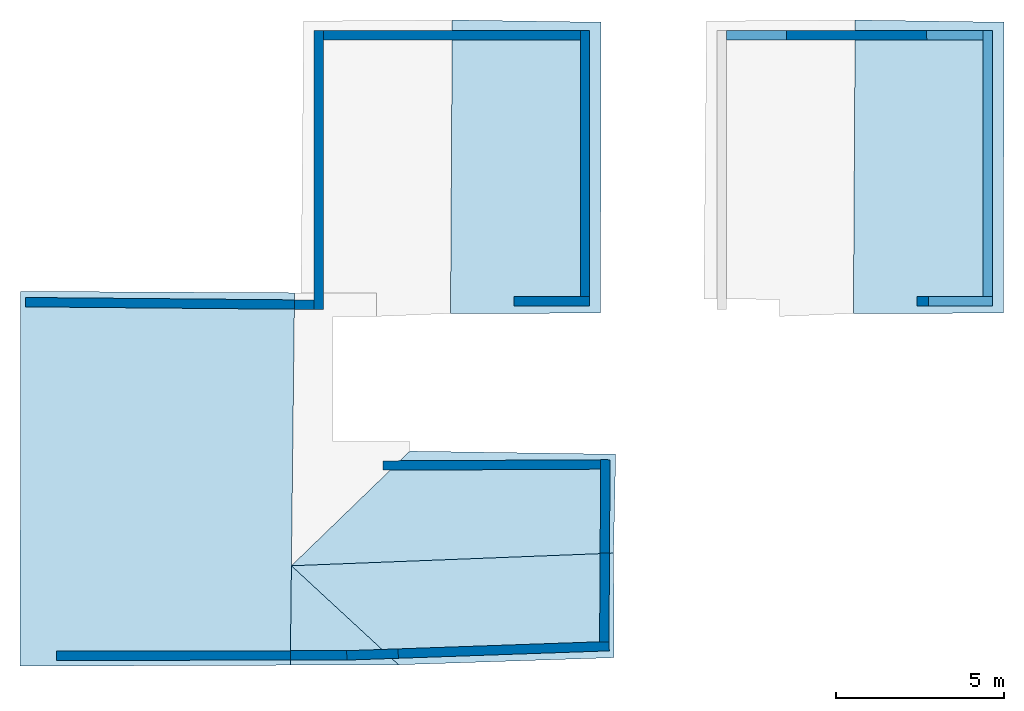
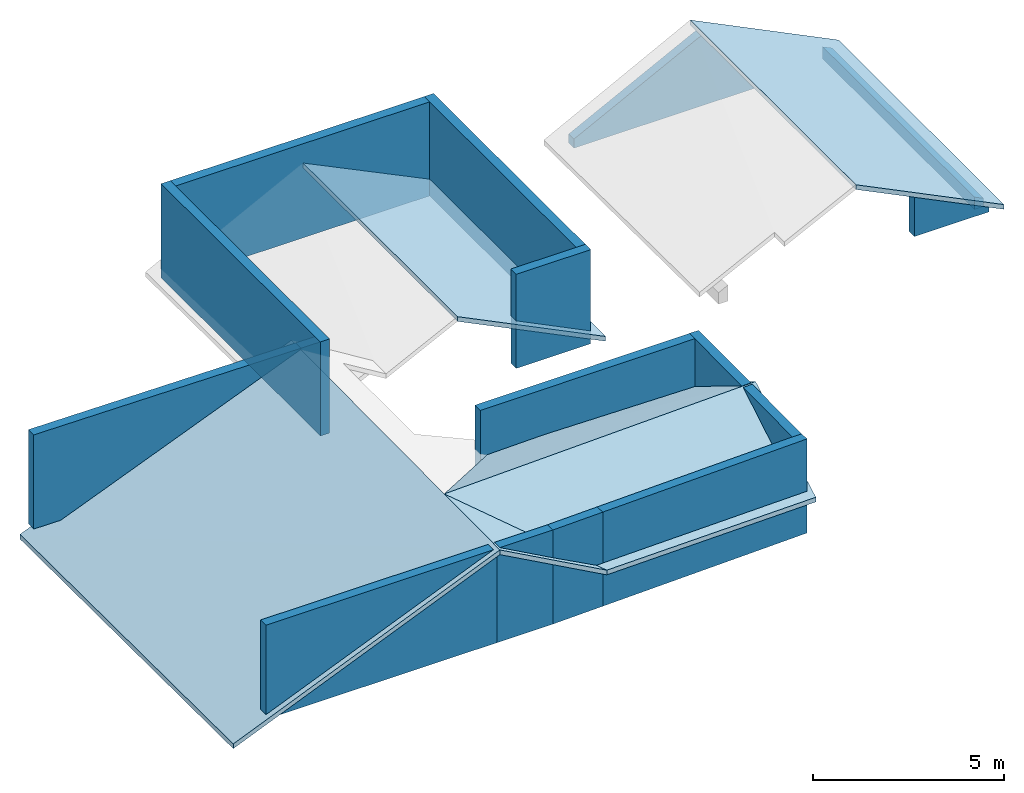
# One storey, part 1 of 2: 28 walls, 8 slabs.
"""IFC4 building model written with IfcOpenShell, lengths in metres."""

from ifc_helpers import new_model, entity, si_unit, converted_unit, frame, frame_2d, origin_with_axes, place, context, subcontext, project, spatial, indexed_curve, outline, extrude, polygons, material, layer, layer_set, layer_usage, type_object, element, save


model = new_model("IFC4")

# Units and contexts
model_context = context("Model", 3, precision=1e-05, world=origin_with_axes())
plan_context = context("Plan", 2, precision=1e-05, world=frame_2d((0.0, 0.0, 0.0), x_axis=(1.0, 0.0, 0.0)))
body_context = subcontext(model_context, "Body", "Model", "MODEL_VIEW")
ifc_project = project(units=[converted_unit("PLANEANGLEUNIT", "degree", entity("IfcReal", 0.0174532925199433), si_unit("PLANEANGLEUNIT", "RADIAN"), dimensions=[0, 0, 0, 0, 0, 0, 0]), si_unit("AREAUNIT", "SQUARE_METRE"), si_unit("VOLUMEUNIT", "CUBIC_METRE"), si_unit("LENGTHUNIT", "METRE")], contexts=[model_context, plan_context])

# Site, building, storey
site_placement = place(None, origin_with_axes())
site = spatial("IfcSite", under=ifc_project, at=site_placement)
building_placement = place(site_placement, origin_with_axes())
building = spatial("IfcBuilding", under=site, at=building_placement, Name="Building")
storey_placement = place(building_placement, frame((0.0, 0.0, 3.0), z_axis=(0.0, 0.0, 1.0), x_axis=(1.0, 0.0, 0.0)))
storey = spatial("IfcBuildingStorey", under=building, at=storey_placement, Name="Dachgeschoss")

# Slabs
slab_1_placement = place(storey_placement, frame((0.138327658176422, 11.9685554504395, -0.0325007438659668), z_axis=(-0.389843016862869, 1.06302975311223e-08, 0.920881330966949), x_axis=(0.920881330966949, -5.23788585837792e-08, 0.389843016862869)))
element("IfcSlab", 1, at=slab_1_placement, inside=storey, Name="roof_wohnen", PredefinedType="ROOF", context=body_context, shape_type="Tessellation", body=[
    polygons([(0.139375194907188, -0.0453592203557491, -0.456899970769882), (0.15936766564846, -11.2182168960571, -0.357028633356094), (0.0808987393975258, -0.0453592240810394, -0.595032215118408), (0.100891202688217, -11.2182168960571, -0.495160847902298), (8.96628284454346, -0.0885668694972992, -0.54577898979187), (8.88335037231445, -11.1898832321167, -0.415635466575623), (8.82487392425537, -11.1898832321167, -0.553767681121826), (8.90780639648438, -0.0885668694972992, -0.683911144733429)], [[[1, 5, 8, 3]], [[1, 3, 4, 2]], [[7, 6, 2, 4]], [[6, 7, 8, 5]], [[1, 6, 5]], [[3, 7, 4]], [[1, 2, 6]], [[3, 8, 7]]]),
])
slab_2_placement = place(storey_placement, frame((7.51337957382202, 18.4299716949463, 3.13837957382202), z_axis=(0.0, 0.0, 1.0), x_axis=(1.0, 0.0, 0.0)))
element("IfcSlab", 2, at=slab_2_placement, inside=storey, PredefinedType="ROOF", context=body_context, shape_type="Tessellation", body=[
    polygons([(0.967490494251251, -17.6513004302979, -0.0905194282531738), (4.19703483581543, -17.6393585205078, -1.87382221221924), (1.00142824649811, -14.6873569488525, -0.113885402679443), (1.00142824649811, -14.6873569488525, -0.263885408639908), (0.967490494251251, -17.6513004302979, -0.240519434213638), (4.19703483581543, -17.6393585205078, -2.02382230758667)], [[[3, 1, 2]], [[4, 6, 5]], [[3, 2, 6, 4]], [[2, 1, 5, 6]], [[1, 3, 4, 5]]]),
])
slab_3_placement = place(storey_placement, frame((11.5073595046997, 19.0338859558105, -0.612094879150391), z_axis=(0.0, 0.0, 1.0), x_axis=(1.0, 0.0, 0.0)))
element("IfcSlab", 3, at=slab_3_placement, inside=storey, Name="dach_n", PredefinedType="ROOF", context=body_context, shape_type="Tessellation", body=[
    polygons([(0.20305597782135, -18.2432727813721, 1.87665224075317), (6.62885904312134, -18.0298824310303, 1.82354259490967), (-2.99255204200745, -15.2912702560425, 3.63658905029297), (6.6104941368103, -14.9145994186401, 3.63154697418213), (-2.99255204200745, -15.2912702560425, 3.48658895492554), (0.20305597782135, -18.2432727813721, 1.72665226459503), (6.62885904312134, -18.0298824310303, 1.67354261875153), (6.6104941368103, -14.9145994186401, 3.4815468788147)], [[[1, 4, 2]], [[6, 8, 5]], [[2, 4, 8, 7]], [[3, 1, 6, 5]], [[4, 3, 5, 8]], [[1, 2, 7, 6]], [[1, 3, 4]], [[6, 7, 8]]]),
])
slab_4_placement = place(storey_placement, frame((11.5073595046997, 19.0338859558105, -0.612094879150391), z_axis=(0.0, 0.0, 1.0), x_axis=(1.0, 0.0, 0.0)))
element("IfcSlab", 4, at=slab_4_placement, inside=storey, Name="dach_s", PredefinedType="ROOF", context=body_context, shape_type="Tessellation", body=[
    polygons([(-2.99255204200745, -15.2912702560425, 3.63658905029297), (6.61049318313599, -14.9145994186401, 3.63154697418213), (0.53916323184967, -11.8741445541382, 1.83055698871613), (6.67501163482666, -11.9667654037476, 1.80503046512604), (0.53916323184967, -11.8741445541382, 1.68055701255798), (-2.99255204200745, -15.2912702560425, 3.48658895492554), (6.61049318313599, -14.9145994186401, 3.4815468788147), (6.67501163482666, -11.9667654037476, 1.6550304889679)], [[[3, 2, 1]], [[7, 5, 6]], [[2, 4, 8, 7]], [[3, 6, 5]], [[4, 3, 5, 8]], [[1, 2, 7, 6]], [[3, 4, 2]], [[7, 8, 5]], [[3, 1, 6]]]),
])
for number, where, z_axis, x_axis, name in (
    (5, (14.0933465957642, 19.4814624786377, 1.75806331634521), (0.83547306060791, 6.05244423468321e-08, 0.54953134059906), (0.54953134059906, 1.12253204065382e-07, -0.83547306060791), "dach_sw"),
    (6, (14.0933465957642, 19.4814624786377, 1.75806331634521), (0.83547306060791, 6.05244423468321e-08, 0.54953134059906), (0.54953134059906, 1.12253204065382e-07, -0.83547306060791), "dach_sw"),
    (7, (14.0933465957642, 19.4814624786377, 1.75806331634521), (0.83547306060791, 6.05244423468321e-08, 0.54953134059906), (0.54953134059906, 1.12253204065382e-07, -0.83547306060791), "dach_sw"),
):
    element("IfcSlab", number, at=place(storey_placement, frame(where, z_axis=z_axis, x_axis=x_axis)), inside=storey, Name=name, PredefinedType="ROOF", context=body_context, shape_type="Tessellation", body=[
        polygons([(-1.04153060913086, -8.217942237854, -0.316155582666397), (3.25821256637573, -8.2083625793457, 2.20982432365417), (-0.953627169132233, 0.529778599739075, -0.311261177062988), (3.28126811981201, 0.463787794113159, 2.21388936042786), (-0.980952382087708, -2.60569453239441, -5.8044319152832), (-0.828306198120117, 0.529778599739075, -0.393690884113312), (-0.916209638118744, -8.217942237854, -0.398585289716721), (3.38353371620178, -8.2083625793457, 2.1273946762085), (3.40658903121948, 0.463787794113159, 2.13145971298218)], [[[1, 4, 2]], [[7, 9, 6]], [[2, 4, 9, 8]], [[3, 1, 7, 6]], [[4, 3, 6, 9]], [[1, 2, 8, 7]], [[1, 3, 4]], [[7, 8, 9]]]),
    ])
slab_5_placement = place(storey_placement, frame((26.103214263916, 19.4814624786377, 1.75806331634521), z_axis=(0.835473120212555, 6.05244707685415e-08, 0.549531161785126), x_axis=(0.549531161785126, 1.1225321117081e-07, -0.835473120212555)))
element("IfcSlab", 8, at=slab_5_placement, inside=storey, Name="dach_sw.001", PredefinedType="ROOF", context=body_context, shape_type="Tessellation", body=[
    polygons([(-1.04153060913086, -8.217942237854, -0.316155582666397), (3.25821256637573, -8.2083625793457, 2.20982432365417), (3.28126811981201, 0.463787794113159, 2.21388936042786), (-0.828306198120117, 0.529778599739075, -0.393690884113312), (-0.916209638118744, -8.217942237854, -0.398585289716721), (3.40658903121948, 0.463787794113159, 2.13145971298218), (3.38353371620178, -8.2083625793457, 2.1273946762085), (-0.953627169132233, 0.529778599739075, -0.311261177062988)], [[[5, 6, 7]], [[6, 4, 8, 3]], [[4, 5, 1, 8]], [[1, 3, 8]], [[7, 2, 1, 5]], [[3, 2, 7, 6]], [[5, 4, 6]], [[1, 2, 3]]]),
])

# Walls
ifc_material = material(Name="aussenwand_280_material")
ifc_layer = layer(ifc_material, 0.280000001192093)
ifc_layer_set = layer_set([ifc_layer])
ifc_layer_usage_1 = layer_usage(ifc_layer_set, "AXIS2", "POSITIVE", 0.0)
wall_type = type_object("IfcWallType", Name="aussenwand_280", PredefinedType="STANDARD", material=ifc_layer_set)
wall_1_placement = place(storey_placement, frame((9.18882751464844, 19.7012138366699, -2.38418579101563e-07), z_axis=(0.0, 0.0, 1.0), x_axis=(-1.62920684942947e-07, -1.0, 0.0)))
element("IfcWall", 9, at=wall_1_placement, inside=storey, type_object=wall_type, material=ifc_layer_usage_1, Name="Wall", PredefinedType="NOTDEFINED", context=body_context, shape_type="SweptSolid", body=[
    extrude(outline(indexed_curve([(0.0, 0.0), (0.0, 0.280000001192093), (8.31982420442171, 0.280000001192093), (8.31982420442171, 0.0), (0.0, 0.0)], self_intersect=False)), origin_with_axes(), (0.0, 0.0, 1.0), 3.0),
])
ifc_layer_usage_2 = layer_usage(ifc_layer_set, "AXIS2", "POSITIVE", 0.0)
wall_2_placement = place(storey_placement, frame((1.50885987281799, 0.922550857067108, -2.38418579101563e-07), z_axis=(0.0, 0.0, 1.0), x_axis=(0.999999582767487, 0.000923240790143609, 0.0)))
element("IfcWall", 10, at=wall_2_placement, inside=storey, type_object=wall_type, material=ifc_layer_usage_2, Name="Wall", PredefinedType="NOTDEFINED", context=body_context, shape_type="SweptSolid", body=[
    extrude(outline(indexed_curve([(0.0, 0.0), (0.0, 0.280000001192093), (6.97187437102741, 0.280000001192093), (6.97187437102741, 0.0), (0.0, 0.0)], self_intersect=False)), origin_with_axes(), (0.0, 0.0, 1.0), 3.0),
])
ifc_layer_usage_3 = layer_usage(ifc_layer_set, "AXIS2", "POSITIVE", 0.0)
wall_3_placement = place(storey_placement, frame((10.1700124740601, 0.931393384933472, -2.38418579101563e-07), z_axis=(0.0, 0.0, 1.0), x_axis=(0.999382197856903, 0.0351415351033211, 0.0)))
element("IfcWall", 11, at=wall_3_placement, inside=storey, type_object=wall_type, material=ifc_layer_usage_3, Name="Wall", PredefinedType="NOTDEFINED", context=body_context, shape_type="SweptSolid", body=[
    extrude(outline(indexed_curve([(0.0, 0.0), (0.0, 0.280000001192093), (1.53450472655644, 0.280000001192093), (1.53450472655644, 0.0), (0.0, 0.0)], self_intersect=False)), origin_with_axes(), (0.0, 0.0, 1.0), 3.0),
])
ifc_layer_usage_4 = layer_usage(ifc_layer_set, "AXIS2", "POSITIVE", 0.0)
wall_4_placement = place(storey_placement, frame((17.7329654693604, 6.90121555328369, -2.38418579101563e-07), z_axis=(0.0, 0.0, 1.0), x_axis=(-0.999989092350006, -0.00467242300510406, 0.0)))
element("IfcWall", 12, at=wall_4_placement, inside=storey, type_object=wall_type, material=ifc_layer_usage_4, Name="Wall", PredefinedType="NOTDEFINED", context=body_context, shape_type="SweptSolid", body=[
    extrude(outline(indexed_curve([(0.0, 0.0), (0.0, 0.280000001192093), (6.4844628440617, 0.280000001192093), (6.4844628440617, 0.0), (0.0, 0.0)], self_intersect=False)), origin_with_axes(), (0.0, 0.0, 1.0), 3.0),
])
ifc_layer_usage_5 = layer_usage(ifc_layer_set, "AXIS2", "POSITIVE", 0.0)
wall_5_placement = place(storey_placement, frame((9.19131374359131, 11.6638669967651, -2.38418579101563e-07), z_axis=(0.0, 0.0, 1.0), x_axis=(-0.999960541725159, 0.00888374913483858, 0.0)))
element("IfcWall", 13, at=wall_5_placement, inside=storey, type_object=wall_type, material=ifc_layer_usage_5, Name="Wall", PredefinedType="NOTDEFINED", context=body_context, shape_type="SweptSolid", body=[
    extrude(outline(indexed_curve([(0.0, 0.0), (0.0, 0.280000001192093), (0.585232937038386, 0.280000001192093), (0.585232937038386, 0.0), (0.0, 0.0)], self_intersect=False)), origin_with_axes(), (0.0, 0.0, 1.0), 3.0),
])
ifc_layer_usage_6 = layer_usage(ifc_layer_set, "AXIS2", "POSITIVE", 0.0)
wall_6_placement = place(storey_placement, frame((9.46882724761963, 19.4212131500244, -2.38418579101563e-07), z_axis=(0.0, 0.0, 1.0), x_axis=(1.0, 0.0, 0.0)))
element("IfcWall", 14, at=wall_6_placement, inside=storey, type_object=wall_type, material=ifc_layer_usage_6, Name="Wall", PredefinedType="NOTDEFINED", context=body_context, shape_type="SweptSolid", body=[
    extrude(outline(indexed_curve([(0.0, 0.0), (0.0, 0.280000001192093), (7.65666477870406, 0.280000001192093), (7.65666477870406, 0.0), (0.0, 0.0)], self_intersect=False)), origin_with_axes(), (0.0, 0.0, 1.0), 3.0),
])
ifc_layer_usage_7 = layer_usage(ifc_layer_set, "AXIS2", "POSITIVE", 0.0)
wall_7_placement = place(storey_placement, frame((17.732982635498, 6.90418434143066, -2.38418579101563e-07), z_axis=(0.0, 0.0, 1.0), x_axis=(-0.00592900207266212, -0.999982416629791, 0.0)))
element("IfcWall", 15, at=wall_7_placement, inside=storey, type_object=wall_type, material=ifc_layer_usage_7, Name="Wall", PredefinedType="NOTDEFINED", context=body_context, shape_type="SweptSolid", body=[
    extrude(outline(indexed_curve([(0.0, 0.0), (0.0, 0.280000001192093), (2.78256681753973, 0.280000001192093), (2.78256681753973, 0.0), (0.0, 0.0)], self_intersect=False)), origin_with_axes(), (0.0, 0.0, 1.0), 3.0),
])
ifc_layer_usage_8 = layer_usage(ifc_layer_set, "AXIS2", "POSITIVE", 0.0)
wall_8_placement = place(storey_placement, frame((15.1564960479736, 11.4919033050537, -2.38418579101563e-07), z_axis=(0.0, 0.0, 1.0), x_axis=(1.0, 0.0, 0.0)))
element("IfcWall", 16, at=wall_8_placement, inside=storey, type_object=wall_type, material=ifc_layer_usage_8, Name="Wall", PredefinedType="NOTDEFINED", context=body_context, shape_type="SweptSolid", body=[
    extrude(outline(indexed_curve([(0.0, 0.0), (0.0, 0.280000001192093), (2.24899481466534, 0.280000001192093), (2.24899481466534, 0.0), (0.0, 0.0)], self_intersect=False)), origin_with_axes(), (0.0, 0.0, 1.0), 3.0),
])
ifc_layer_usage_9 = layer_usage(ifc_layer_set, "AXIS2", "POSITIVE", 0.0)
wall_9_placement = place(storey_placement, frame((17.1254920959473, 19.7012138366699, -2.38418579101563e-07), z_axis=(0.0, 0.0, 1.0), x_axis=(-1.62920684942947e-07, -1.0, 0.0)))
element("IfcWall", 17, at=wall_9_placement, inside=storey, type_object=wall_type, material=ifc_layer_usage_9, Name="Wall", PredefinedType="NOTDEFINED", context=body_context, shape_type="SweptSolid", body=[
    extrude(outline(indexed_curve([(0.0, 0.0), (0.0, 0.280000001192093), (7.92931081694632, 0.280000001192093), (7.92931081694632, 0.0), (0.0, 0.0)], self_intersect=False)), origin_with_axes(), (0.0, 0.0, 1.0), 3.0),
])
ifc_layer_usage_10 = layer_usage(ifc_layer_set, "AXIS2", "POSITIVE", 0.0)
wall_10_placement = place(storey_placement, frame((8.4807300567627, 0.929833590984344, -2.38418579101563e-07), z_axis=(0.0, 0.0, 1.0), x_axis=(0.999999582767487, 0.000923240790143609, 0.0)))
element("IfcWall", 18, at=wall_10_placement, inside=storey, type_object=wall_type, material=ifc_layer_usage_10, Name="Wall", PredefinedType="NOTDEFINED", context=body_context, shape_type="SweptSolid", body=[
    extrude(outline(indexed_curve([(0.0, 0.0), (0.0, 0.280000001192093), (1.68927835094324, 0.280000001192093), (1.68927835094324, 0.0), (0.0, 0.0)], self_intersect=False)), origin_with_axes(), (0.0, 0.0, 1.0), 3.0),
])
ifc_layer_usage_11 = layer_usage(ifc_layer_set, "AXIS2", "POSITIVE", 0.0)
wall_11_placement = place(storey_placement, frame((11.7035694122314, 0.985318243503571, -2.38418579101563e-07), z_axis=(0.0, 0.0, 1.0), x_axis=(0.999382138252258, 0.0351415351033211, 0.0)))
element("IfcWall", 19, at=wall_11_placement, inside=storey, type_object=wall_type, material=ifc_layer_usage_11, Name="Wall", PredefinedType="NOTDEFINED", context=body_context, shape_type="SweptSolid", body=[
    extrude(outline(indexed_curve([(0.0, 0.0), (0.0, 0.280000001192093), (6.29101780503812, 0.280000001192093), (6.29101780503812, 0.0), (0.0, 0.0)], self_intersect=False)), origin_with_axes(), (0.0, 0.0, 1.0), 3.0),
])
ifc_layer_usage_12 = layer_usage(ifc_layer_set, "AXIS2", "POSITIVE", 0.0)
wall_12_placement = place(storey_placement, frame((17.7164840698242, 4.121666431427, -2.38418579101563e-07), z_axis=(0.0, 0.0, 1.0), x_axis=(-0.00592900207266212, -0.999982416629791, 0.0)))
element("IfcWall", 20, at=wall_12_placement, inside=storey, type_object=wall_type, material=ifc_layer_usage_12, Name="Wall", PredefinedType="NOTDEFINED", context=body_context, shape_type="SweptSolid", body=[
    extrude(outline(indexed_curve([(0.0, 0.0), (0.0, 0.280000001192093), (2.64533971893712, 0.280000001192093), (2.64533971893712, 0.0), (0.0, 0.0)], self_intersect=False)), origin_with_axes(), (0.0, 0.0, 1.0), 3.0),
])
ifc_layer_usage_13 = layer_usage(ifc_layer_set, "AXIS2", "POSITIVE", 0.0)
wall_13_placement = place(storey_placement, frame((8.60610389709473, 11.6690664291382, -0.0010533332824707), z_axis=(0.0, 0.0, 1.0), x_axis=(-0.999960541725159, 0.00888374913483858, 0.0)))
element("IfcWall", 21, at=wall_13_placement, inside=storey, type_object=wall_type, material=ifc_layer_usage_13, Name="Wall", PredefinedType="NOTDEFINED", context=body_context, shape_type="SweptSolid", body=[
    extrude(outline(indexed_curve([(0.0, 0.0), (0.0, 0.280000001192093), (8.01390124085017, 0.280000001192093), (8.01390124085017, 0.0), (0.0, 0.0)], self_intersect=False)), origin_with_axes(), (0.0, 0.0, 1.0), 3.0),
])
ifc_layer_usage_14 = layer_usage(ifc_layer_set, "AXIS2", "POSITIVE", 0.0)
wall_14_placement = place(storey_placement, frame((15.1564960479736, 11.4919033050537, -2.38418579101563e-07), z_axis=(0.0, 0.0, 1.0), x_axis=(1.0, 0.0, 0.0)))
element("IfcWall", 22, at=wall_14_placement, inside=storey, type_object=wall_type, material=ifc_layer_usage_14, Name="Wall", PredefinedType="NOTDEFINED", context=body_context, shape_type="SweptSolid", body=[
    extrude(outline(indexed_curve([(0.0, 0.0), (0.0, 0.280000001192093), (2.24899481466534, 0.280000001192093), (2.24899481466534, 0.0), (0.0, 0.0)], self_intersect=False)), origin_with_axes(), (0.0, 0.0, 1.0), 3.0),
])
ifc_layer_usage_15 = layer_usage(ifc_layer_set, "AXIS2", "POSITIVE", 0.0)
wall_15_placement = place(storey_placement, frame((17.1254920959473, 19.7012138366699, -2.38418579101563e-07), z_axis=(0.0, 0.0, 1.0), x_axis=(-1.62920684942947e-07, -1.0, 0.0)))
element("IfcWall", 23, at=wall_15_placement, inside=storey, type_object=wall_type, material=ifc_layer_usage_15, Name="Wall", PredefinedType="NOTDEFINED", context=body_context, shape_type="SweptSolid", body=[
    extrude(outline(indexed_curve([(0.0, 0.0), (0.0, 0.280000001192093), (7.92931081694632, 0.280000001192093), (7.92931081694632, 0.0), (0.0, 0.0)], self_intersect=False)), origin_with_axes(), (0.0, 0.0, 1.0), 3.0),
])
ifc_layer_usage_16 = layer_usage(ifc_layer_set, "AXIS2", "POSITIVE", 0.0)
wall_16_placement = place(storey_placement, frame((9.46882724761963, 19.4212131500244, -2.38418579101563e-07), z_axis=(0.0, 0.0, 1.0), x_axis=(1.0, 0.0, 0.0)))
element("IfcWall", 24, at=wall_16_placement, inside=storey, type_object=wall_type, material=ifc_layer_usage_16, Name="Wall", PredefinedType="NOTDEFINED", context=body_context, shape_type="SweptSolid", body=[
    extrude(outline(indexed_curve([(0.0, 0.0), (0.0, 0.280000001192093), (7.65666477870406, 0.280000001192093), (7.65666477870406, 0.0), (0.0, 0.0)], self_intersect=False)), origin_with_axes(), (0.0, 0.0, 1.0), 3.0),
])
ifc_layer_usage_17 = layer_usage(ifc_layer_set, "AXIS2", "POSITIVE", 0.0)
wall_17_placement = place(storey_placement, frame((9.18882751464844, 19.7012138366699, -2.38418579101563e-07), z_axis=(0.0, 0.0, 1.0), x_axis=(-1.62920684942947e-07, -1.0, 0.0)))
element("IfcWall", 25, at=wall_17_placement, inside=storey, type_object=wall_type, material=ifc_layer_usage_17, Name="Wall", PredefinedType="NOTDEFINED", context=body_context, shape_type="SweptSolid", body=[
    extrude(outline(indexed_curve([(0.0, 0.0), (0.0, 0.280000001192093), (8.31982420442171, 0.280000001192093), (8.31982420442171, 0.0), (0.0, 0.0)], self_intersect=False)), origin_with_axes(), (0.0, 0.0, 1.0), 3.0),
])
ifc_layer_usage_18 = layer_usage(ifc_layer_set, "AXIS2", "POSITIVE", 0.0)
wall_18_placement = place(storey_placement, frame((15.1564960479736, 11.4919033050537, -2.38418579101563e-07), z_axis=(0.0, 0.0, 1.0), x_axis=(1.0, 0.0, 0.0)))
element("IfcWall", 26, at=wall_18_placement, inside=storey, type_object=wall_type, material=ifc_layer_usage_18, Name="Wall", PredefinedType="NOTDEFINED", context=body_context, shape_type="SweptSolid", body=[
    extrude(outline(indexed_curve([(0.0, 0.0), (0.0, 0.280000001192093), (2.24899481466534, 0.280000001192093), (2.24899481466534, 0.0), (0.0, 0.0)], self_intersect=False)), origin_with_axes(), (0.0, 0.0, 1.0), 3.0),
])
ifc_layer_usage_19 = layer_usage(ifc_layer_set, "AXIS2", "POSITIVE", 0.0)
wall_19_placement = place(storey_placement, frame((17.1254920959473, 19.7012138366699, -2.38418579101563e-07), z_axis=(0.0, 0.0, 1.0), x_axis=(-1.62920684942947e-07, -1.0, 0.0)))
element("IfcWall", 27, at=wall_19_placement, inside=storey, type_object=wall_type, material=ifc_layer_usage_19, Name="Wall", PredefinedType="NOTDEFINED", context=body_context, shape_type="SweptSolid", body=[
    extrude(outline(indexed_curve([(0.0, 0.0), (0.0, 0.280000001192093), (7.92931081694632, 0.280000001192093), (7.92931081694632, 0.0), (0.0, 0.0)], self_intersect=False)), origin_with_axes(), (0.0, 0.0, 1.0), 3.0),
])
ifc_layer_usage_20 = layer_usage(ifc_layer_set, "AXIS2", "POSITIVE", 0.0)
wall_20_placement = place(storey_placement, frame((9.46882724761963, 19.4212131500244, -2.38418579101563e-07), z_axis=(0.0, 0.0, 1.0), x_axis=(1.0, 0.0, 0.0)))
element("IfcWall", 28, at=wall_20_placement, inside=storey, type_object=wall_type, material=ifc_layer_usage_20, Name="Wall", PredefinedType="NOTDEFINED", context=body_context, shape_type="SweptSolid", body=[
    extrude(outline(indexed_curve([(0.0, 0.0), (0.0, 0.280000001192093), (7.65666477870406, 0.280000001192093), (7.65666477870406, 0.0), (0.0, 0.0)], self_intersect=False)), origin_with_axes(), (0.0, 0.0, 1.0), 3.0),
])
ifc_layer_usage_21 = layer_usage(ifc_layer_set, "AXIS2", "POSITIVE", 0.0)
wall_21_placement = place(storey_placement, frame((9.18882751464844, 19.7012138366699, -2.38418579101563e-07), z_axis=(0.0, 0.0, 1.0), x_axis=(-1.62920684942947e-07, -1.0, 0.0)))
element("IfcWall", 29, at=wall_21_placement, inside=storey, type_object=wall_type, material=ifc_layer_usage_21, Name="Wall", PredefinedType="NOTDEFINED", context=body_context, shape_type="SweptSolid", body=[
    extrude(outline(indexed_curve([(0.0, 0.0), (0.0, 0.280000001192093), (8.31982420442171, 0.280000001192093), (8.31982420442171, 0.0), (0.0, 0.0)], self_intersect=False)), origin_with_axes(), (0.0, 0.0, 1.0), 3.0),
])
ifc_layer_usage_22 = layer_usage(ifc_layer_set, "AXIS2", "POSITIVE", 0.0)
wall_22_placement = place(storey_placement, frame((15.1564960479736, 11.4919033050537, -2.38418579101563e-07), z_axis=(0.0, 0.0, 1.0), x_axis=(1.0, 0.0, 0.0)))
element("IfcWall", 30, at=wall_22_placement, inside=storey, type_object=wall_type, material=ifc_layer_usage_22, Name="Wall", PredefinedType="NOTDEFINED", context=body_context, shape_type="SweptSolid", body=[
    extrude(outline(indexed_curve([(0.0, 0.0), (0.0, 0.280000001192093), (2.24899481466534, 0.280000001192093), (2.24899481466534, 0.0), (0.0, 0.0)], self_intersect=False)), origin_with_axes(), (0.0, 0.0, 1.0), 3.0),
])
ifc_layer_usage_23 = layer_usage(ifc_layer_set, "AXIS2", "POSITIVE", 0.0)
wall_23_placement = place(storey_placement, frame((17.1254920959473, 19.7012138366699, -2.38418579101563e-07), z_axis=(0.0, 0.0, 1.0), x_axis=(-1.62920684942947e-07, -1.0, 0.0)))
element("IfcWall", 31, at=wall_23_placement, inside=storey, type_object=wall_type, material=ifc_layer_usage_23, Name="Wall", PredefinedType="NOTDEFINED", context=body_context, shape_type="SweptSolid", body=[
    extrude(outline(indexed_curve([(0.0, 0.0), (0.0, 0.280000001192093), (7.92931081694632, 0.280000001192093), (7.92931081694632, 0.0), (0.0, 0.0)], self_intersect=False)), origin_with_axes(), (0.0, 0.0, 1.0), 3.0),
])
ifc_layer_usage_24 = layer_usage(ifc_layer_set, "AXIS2", "POSITIVE", 0.0)
wall_24_placement = place(storey_placement, frame((9.46882724761963, 19.4212131500244, -2.38418579101563e-07), z_axis=(0.0, 0.0, 1.0), x_axis=(1.0, 0.0, 0.0)))
element("IfcWall", 32, at=wall_24_placement, inside=storey, type_object=wall_type, material=ifc_layer_usage_24, Name="Wall", PredefinedType="NOTDEFINED", context=body_context, shape_type="SweptSolid", body=[
    extrude(outline(indexed_curve([(0.0, 0.0), (0.0, 0.280000001192093), (7.65666477870406, 0.280000001192093), (7.65666477870406, 0.0), (0.0, 0.0)], self_intersect=False)), origin_with_axes(), (0.0, 0.0, 1.0), 3.0),
])
ifc_layer_usage_25 = layer_usage(ifc_layer_set, "AXIS2", "POSITIVE", 0.0)
wall_25_placement = place(storey_placement, frame((9.18882751464844, 19.7012138366699, -2.38418579101563e-07), z_axis=(0.0, 0.0, 1.0), x_axis=(-1.62920684942947e-07, -1.0, 0.0)))
element("IfcWall", 33, at=wall_25_placement, inside=storey, type_object=wall_type, material=ifc_layer_usage_25, Name="Wall", PredefinedType="NOTDEFINED", context=body_context, shape_type="SweptSolid", body=[
    extrude(outline(indexed_curve([(0.0, 0.0), (0.0, 0.280000001192093), (8.31982420442171, 0.280000001192093), (8.31982420442171, 0.0), (0.0, 0.0)], self_intersect=False)), origin_with_axes(), (0.0, 0.0, 1.0), 3.0),
])
wall_26_placement = place(storey_placement, frame((29.1353607177734, 19.7012138366699, -2.38418579101562e-07), z_axis=(0.0, 0.0, 1.0), x_axis=(-1.62920684942947e-07, -1.0, 0.0)))
element("IfcWall", 34, at=wall_26_placement, inside=storey, Name="Wall.017", PredefinedType="ELEMENTEDWALL", context=body_context, shape_type="Tessellation", body=[
    polygons([(0.0, 0.0, 0.0), (0.0, 0.280000001192093, 0.0), (7.92931079864502, 0.280000001192093, 0.0), (7.92931079864502, 0.0, 0.0), (7.92931079864502, 0.0, 0.3976731300354), (7.92931079864502, 0.280000001192093, 0.25970184803009), (0.0, 0.0, 0.385388821363449), (0.0, 0.280000001192093, 0.249655932188034)], [[[5, 4, 3, 6]], [[7, 1, 4, 5]], [[2, 1, 7, 8]], [[4, 1, 2, 3]], [[3, 2, 8, 6]]]),
    polygons([(0.0, 0.0, 0.0), (0.0, 0.280000001192093, 0.0), (7.92931079864502, 0.280000001192093, 0.0), (7.92931079864502, 0.0, 0.0), (7.92931079864502, 0.0, 0.3976731300354), (7.92931079864502, 0.280000001192093, 0.25970184803009), (0.0, 0.0, 0.385388821363449), (0.0, 0.280000001192093, 0.249655932188034)], [[[7, 6, 8]], [[7, 5, 6]]]),
])
wall_27_placement = place(storey_placement, frame((21.4786949157715, 19.4212131500244, -2.38418579101562e-07), z_axis=(0.0, 0.0, 1.0), x_axis=(1.0, 0.0, 0.0)))
element("IfcWall", 35, at=wall_27_placement, inside=storey, Name="Wall.018", PredefinedType="ELEMENTEDWALL", context=body_context, shape_type="Tessellation", body=[
    polygons([(0.0, 0.0, 0.0), (0.0, 0.280000001192093, 0.0), (7.65666484832764, 0.280000001192093, 0.0), (7.65666484832764, 0.0, 0.0), (7.65666484832764, 0.0, 0.386841058731079), (7.65666484832764, 0.280000001192093, 0.385389387607574), (3.83688712120056, 0.0, 2.23851776123047), (3.83856415748596, 0.280000001192093, 2.23625302314758), (0.0, 0.0, 0.290171056985855), (3.83688688278198, 0.0, 2.23851752281189), (3.68027377128601, 0.0, 2.16813325881958), (0.0, 0.280000001192093, 0.282527238130569), (3.83856391906738, 0.280000001192093, 2.236252784729), (3.75627207756042, 0.280000001192093, 2.19926977157593)], [[[5, 4, 3, 6]], [[2, 1, 9, 12]], [[4, 1, 2, 3]], [[2, 12, 14, 13, 8, 6, 3]], [[5, 7, 10, 11, 9, 1, 4]]]),
    polygons([(0.0, 0.0, 0.0), (0.0, 0.280000001192093, 0.0), (7.65666484832764, 0.280000001192093, 0.0), (7.65666484832764, 0.0, 0.0), (7.65666484832764, 0.0, 0.386841058731079), (7.65666484832764, 0.280000001192093, 0.385389387607574), (3.83688712120056, 0.0, 2.23851776123047), (3.83856415748596, 0.280000001192093, 2.23625302314758), (0.0, 0.0, 0.290171056985855), (3.83688688278198, 0.0, 2.23851752281189), (3.68027377128601, 0.0, 2.16813325881958), (0.0, 0.280000001192093, 0.282527238130569), (3.83856391906738, 0.280000001192093, 2.236252784729), (3.75627207756042, 0.280000001192093, 2.19926977157593)], [[[8, 7, 5, 6]], [[12, 9, 11, 14]], [[14, 11, 10, 13]]]),
])
wall_28_placement = place(storey_placement, frame((27.1663627624512, 11.4919033050537, -2.38418579101562e-07), z_axis=(0.0, 0.0, 1.0), x_axis=(1.0, 0.0, 0.0)))
element("IfcWall", 36, at=wall_28_placement, inside=storey, Name="Wall.016", PredefinedType="ELEMENTEDWALL", context=body_context, shape_type="Tessellation", body=[
    polygons([(0.0, 0.0, 0.0), (0.0, 0.280000001192093, 0.0), (2.24899482727051, 0.280000001192093, 0.0), (2.24899482727051, 0.0, 0.0), (2.24899482727051, 0.0, 0.259997576475143), (2.24899482727051, 0.280000001192093, 0.259703397750854), (0.0, 0.0, 1.36820006370544), (0.0, 0.280000001192093, 1.36790585517883)], [[[5, 4, 3, 6]], [[7, 1, 4, 5]], [[2, 1, 7, 8]], [[4, 1, 2, 3]], [[3, 2, 8, 6]]]),
    polygons([(0.0, 0.0, 0.0), (0.0, 0.280000001192093, 0.0), (2.24899482727051, 0.280000001192093, 0.0), (2.24899482727051, 0.0, 0.0), (2.24899482727051, 0.0, 0.259997576475143), (2.24899482727051, 0.280000001192093, 0.259703397750854), (0.0, 0.0, 1.36820006370544), (0.0, 0.280000001192093, 1.36790585517883)], [[[5, 6, 8, 7]]]),
])

save(model, "model.ifc")
